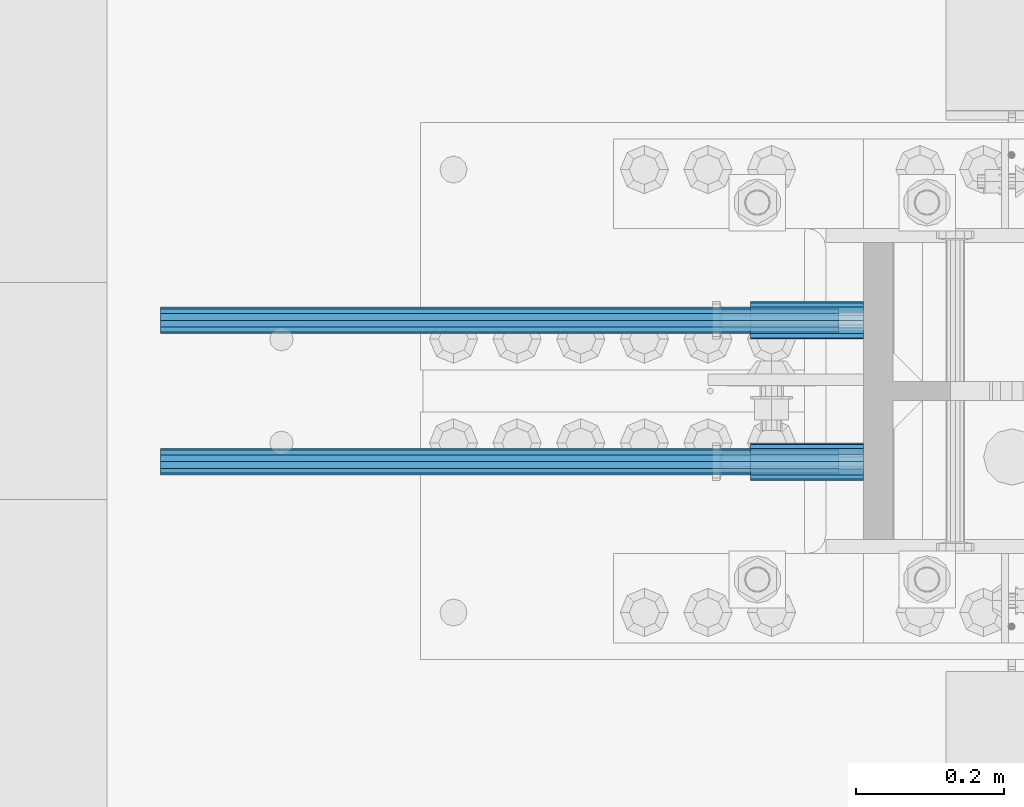
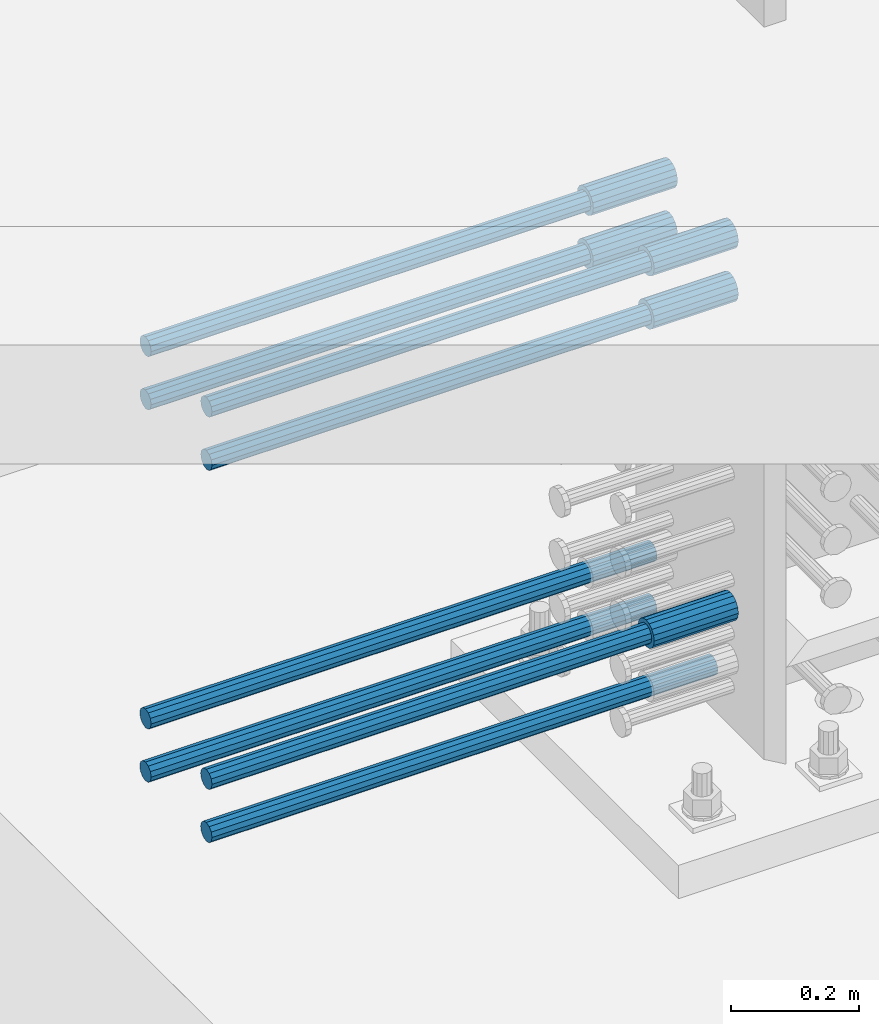
# One storey, part 1236 of 1763: 13 beams, 9 elements without a shape of their own.
"""IFC2X3 building model written with IfcOpenShell, lengths in millimetres."""

from ifc_helpers import new_model, si_unit, frame, origin_with_axes, place, context, subcontext, project, spatial, faceted_brep, material, type_object, element, aggregate, save


model = new_model("IFC2X3")

# Units and contexts
model_context = context("Model", 3, precision=1e-05, world=origin_with_axes())
body_context = subcontext(model_context, "Body", "Model", "MODEL_VIEW")
ifc_project = project(units=[si_unit("LENGTHUNIT", "METRE", prefix="MILLI"), si_unit("AREAUNIT", "SQUARE_METRE"), si_unit("VOLUMEUNIT", "CUBIC_METRE"), si_unit("MASSUNIT", "GRAM", prefix="KILO"), si_unit("TIMEUNIT", "SECOND"), si_unit("PLANEANGLEUNIT", "RADIAN"), si_unit("SOLIDANGLEUNIT", "STERADIAN"), si_unit("THERMODYNAMICTEMPERATUREUNIT", "DEGREE_CELSIUS"), si_unit("LUMINOUSINTENSITYUNIT", "LUMEN")], contexts=[model_context])

# Site, building, storey
site_placement = place(None, origin_with_axes())
site = spatial("IfcSite", under=ifc_project, at=site_placement, CompositionType="ELEMENT")
building_placement = place(site_placement, origin_with_axes())
building = spatial("IfcBuilding", under=site, at=building_placement, Name="Undefined", CompositionType="ELEMENT")
storey_placement = place(building_placement, origin_with_axes())
storey = spatial("IfcBuildingStorey", under=building, at=storey_placement, Name="Undefined", CompositionType="ELEMENT", Elevation=0.0)

# Assembly, beams
assembly_1_placement = place(storey_placement, origin_with_axes())
assembly_1 = element("IfcElementAssembly", 1, at=assembly_1_placement, inside=storey, Name="COLUMN", AssemblyPlace="NOTDEFINED", PredefinedType="RIGID_FRAME")
ifc_material = material(Name="STEEL/A706-GR.80")
beam_type_1 = type_object("IfcBeamType", PredefinedType="NOTDEFINED")
beam_1_placement = place(assembly_1_placement, frame((-35149.8622736972, 361.950000000843, 4165.60000000002), z_axis=(0.0, 0.0, 1.0), x_axis=(-1.0, 0.0, 0.0)))
beam_1 = element("IfcBeam", 2, at=beam_1_placement, type_object=beam_type_1, material=ifc_material, Name="HALF COUPLER F", context=body_context, shape_type="Brep", body=[
    faceted_brep([(32.7659999999996, -8.95349999999962, -15.507916905568), (32.7659999999996, 0.0, -17.9070000000002), (32.7659999999996, 8.95349999999962, -15.507916905568), (32.7659999999996, 15.507916905568, -8.95350000000008), (32.7659999999996, 17.9069999999992, 0.0), (32.7659999999996, 15.507916905568, 8.95350000000008), (32.7659999999996, 8.95349999999962, 15.507916905568), (32.7659999999996, 0.0, 17.9070000000002), (32.7659999999996, -8.95349999999962, 15.507916905568), (32.7659999999996, -15.507916905568, 8.95350000000008), (32.7659999999996, -17.9069999999992, 0.0), (32.7659999999996, -15.507916905568, -8.95350000000008), (152.400103102711, -15.507916905568, 8.95350000000008), (152.400103102711, -8.95349999999962, 15.507916905568), (152.400103102711, -17.9069999999992, 0.0), (152.400103102711, -15.507916905568, -8.95350000000008), (152.400103102711, -8.95349999999962, -15.507916905568), (152.400103102711, 0.0, -17.9070000000002), (152.400103102711, 8.95349999999962, -15.507916905568), (152.400103102711, 15.507916905568, -8.95350000000008), (152.400103102711, 17.9069999999992, 0.0), (152.400103102711, 15.507916905568, 8.95350000000008), (152.400103102711, 8.95349999999962, 15.507916905568), (152.400103102711, 0.0, 17.9070000000002), (0.0, -23.466540125788, 9.72015918207308), (0.0, -17.9605122421381, 17.9605122421385), (0.0, -9.72015918207398, 23.4665401257867), (0.0, 0.0, 25.4000000000001), (0.0, 9.72015918207398, 23.4665401257867), (0.0, 17.9605122421381, 17.9605122421385), (0.0, 23.466540125788, 9.72015918207308), (0.0, 25.4000000000015, 0.0), (0.0, 23.466540125788, -9.72015918207308), (0.0, 17.9605122421381, -17.9605122421385), (0.0, 9.72015918207398, -23.4665401257867), (0.0, 0.0, -25.4000000000001), (0.0, -9.72015918207398, -23.4665401257867), (0.0, -17.9605122421381, -17.9605122421385), (0.0, -23.466540125788, -9.72015918207308), (0.0, -25.4000000000015, 0.0), (152.400103102711, -25.4000000000015, 0.0), (152.400103102711, -23.466540125788, 9.72015918207308), (152.400103102711, -17.9605122421381, 17.9605122421385), (152.400103102711, -9.72015918207398, 23.4665401257867), (152.400103102711, 0.0, 25.4000000000001), (152.400103102711, 9.72015918207398, 23.4665401257867), (152.400103102711, 17.9605122421381, 17.9605122421385), (152.400103102711, 23.466540125788, 9.72015918207308), (152.400103102711, 25.4000000000015, 0.0), (152.400103102711, 23.466540125788, -9.72015918207308), (152.400103102711, 17.9605122421381, -17.9605122421385), (152.400103102711, 9.72015918207398, -23.4665401257867), (152.400103102711, 0.0, -25.4000000000001), (152.400103102711, -9.72015918207398, -23.4665401257867), (152.400103102711, -17.9605122421381, -17.9605122421385), (152.400103102711, -23.466540125788, -9.72015918207308)], [[[0, 1, 2, 3, 4, 5, 6, 7, 8, 9, 10, 11]], [[12, 9, 8, 13]], [[14, 10, 9, 12]], [[15, 11, 10, 14]], [[16, 0, 11, 15]], [[17, 1, 0, 16]], [[18, 2, 1, 17]], [[19, 3, 2, 18]], [[20, 4, 3, 19]], [[21, 5, 4, 20]], [[22, 6, 5, 21]], [[23, 7, 6, 22]], [[13, 8, 7, 23]], [[24, 25, 26, 27, 28, 29, 30, 31, 32, 33, 34, 35, 36, 37, 38, 39]], [[24, 39, 40, 41]], [[25, 24, 41, 42]], [[26, 25, 42, 43]], [[27, 26, 43, 44]], [[28, 27, 44, 45]], [[29, 28, 45, 46]], [[30, 29, 46, 47]], [[31, 30, 47, 48]], [[32, 31, 48, 49]], [[33, 32, 49, 50]], [[34, 33, 50, 51]], [[35, 34, 51, 52]], [[36, 35, 52, 53]], [[37, 36, 53, 54]], [[38, 37, 54, 55]], [[39, 38, 55, 40]], [[54, 53, 52, 51, 50, 49, 48, 47, 46, 45, 44, 43, 42, 41, 40, 55], [21, 20, 19, 18, 17, 16, 15, 14, 12, 13, 23, 22]]]),
])
beam_2_placement = place(assembly_1_placement, frame((-35149.862342359, 552.450000000255, 4775.20000000008), z_axis=(0.0, 0.0, 1.0), x_axis=(-1.0, 0.0, 0.0)))
beam_2 = element("IfcBeam", 3, at=beam_2_placement, type_object=beam_type_1, material=ifc_material, Name="HALF COUPLER", context=body_context, shape_type="Brep", body=[
    faceted_brep([(0.0, -25.4000000000015, 0.0), (0.0, -23.466540125788, -9.72015918207308), (152.400103102711, -23.466540125788, -9.72015918207308), (152.400103102711, -25.4000000000015, 0.0), (0.0, -17.9605122421381, -17.9605122421385), (152.400103102711, -17.9605122421381, -17.9605122421385), (0.0, -9.72015918207398, -23.4665401257867), (152.400103102711, -9.72015918207398, -23.4665401257867), (0.0, 0.0, -25.4000000000001), (152.400103102711, 0.0, -25.4000000000001), (0.0, 9.72015918207398, -23.4665401257867), (152.400103102711, 9.72015918207398, -23.4665401257867), (0.0, 17.9605122421381, -17.9605122421385), (152.400103102711, 17.9605122421381, -17.9605122421385), (0.0, 23.466540125788, -9.72015918207308), (152.400103102711, 23.466540125788, -9.72015918207308), (0.0, 25.4000000000015, 0.0), (152.400103102711, 25.4000000000015, 0.0), (0.0, 23.466540125788, 9.72015918207308), (152.400103102711, 23.466540125788, 9.72015918207308), (0.0, 17.9605122421381, 17.9605122421385), (152.400103102711, 17.9605122421381, 17.9605122421385), (0.0, 9.72015918207398, 23.4665401257867), (152.400103102711, 9.72015918207398, 23.4665401257867), (0.0, 0.0, 25.4000000000001), (152.400103102711, 0.0, 25.4000000000001), (0.0, -9.72015918207398, 23.4665401257867), (152.400103102711, -9.72015918207398, 23.4665401257867), (0.0, -17.9605122421381, 17.9605122421385), (152.400103102711, -17.9605122421381, 17.9605122421385), (0.0, -23.466540125788, 9.72015918207308), (152.400103102711, -23.466540125788, 9.72015918207308)], [[[0, 1, 2, 3]], [[1, 4, 5, 2]], [[4, 6, 7, 5]], [[6, 8, 9, 7]], [[8, 10, 11, 9]], [[10, 12, 13, 11]], [[12, 14, 15, 13]], [[14, 16, 17, 15]], [[16, 18, 19, 17]], [[18, 20, 21, 19]], [[20, 22, 23, 21]], [[22, 24, 25, 23]], [[24, 26, 27, 25]], [[26, 28, 29, 27]], [[28, 30, 31, 29]], [[30, 0, 3, 31]], [[5, 7, 9, 11, 13, 15, 17, 19, 21, 23, 25, 27, 29, 31, 3, 2]], [[30, 28, 26, 24, 22, 20, 18, 16, 14, 12, 10, 8, 6, 4, 1, 0]]]),
])
beam_3_placement = place(assembly_1_placement, frame((-35149.8622736972, 361.950000000843, 4775.20000000008), z_axis=(0.0, 0.0, 1.0), x_axis=(-1.0, 0.0, 0.0)))
beam_3 = element("IfcBeam", 4, at=beam_3_placement, type_object=beam_type_1, material=ifc_material, Name="HALF COUPLER F", context=body_context, shape_type="Brep", body=[
    faceted_brep([(32.7659999999996, -8.95349999999962, -15.507916905568), (32.7659999999996, 0.0, -17.9070000000002), (32.7659999999996, 8.95349999999962, -15.507916905568), (32.7659999999996, 15.507916905568, -8.95350000000008), (32.7659999999996, 17.9069999999992, 0.0), (32.7659999999996, 15.507916905568, 8.95350000000008), (32.7659999999996, 8.95349999999962, 15.507916905568), (32.7659999999996, 0.0, 17.9070000000002), (32.7659999999996, -8.95349999999962, 15.507916905568), (32.7659999999996, -15.507916905568, 8.95350000000008), (32.7659999999996, -17.9069999999992, 0.0), (32.7659999999996, -15.507916905568, -8.95350000000008), (152.400103102711, -15.507916905568, 8.95350000000008), (152.400103102711, -8.95349999999962, 15.507916905568), (152.400103102711, -17.9069999999992, 0.0), (152.400103102711, -15.507916905568, -8.95350000000008), (152.400103102711, -8.95349999999962, -15.507916905568), (152.400103102711, 0.0, -17.9070000000002), (152.400103102711, 8.95349999999962, -15.507916905568), (152.400103102711, 15.507916905568, -8.95350000000008), (152.400103102711, 17.9069999999992, 0.0), (152.400103102711, 15.507916905568, 8.95350000000008), (152.400103102711, 8.95349999999962, 15.507916905568), (152.400103102711, 0.0, 17.9070000000002), (0.0, -23.466540125788, 9.72015918207308), (0.0, -17.9605122421381, 17.9605122421385), (0.0, -9.72015918207398, 23.4665401257867), (0.0, 0.0, 25.4000000000001), (0.0, 9.72015918207398, 23.4665401257867), (0.0, 17.9605122421381, 17.9605122421385), (0.0, 23.466540125788, 9.72015918207308), (0.0, 25.4000000000015, 0.0), (0.0, 23.466540125788, -9.72015918207308), (0.0, 17.9605122421381, -17.9605122421385), (0.0, 9.72015918207398, -23.4665401257867), (0.0, 0.0, -25.4000000000001), (0.0, -9.72015918207398, -23.4665401257867), (0.0, -17.9605122421381, -17.9605122421385), (0.0, -23.466540125788, -9.72015918207308), (0.0, -25.4000000000015, 0.0), (152.400103102711, -25.4000000000015, 0.0), (152.400103102711, -23.466540125788, 9.72015918207308), (152.400103102711, -17.9605122421381, 17.9605122421385), (152.400103102711, -9.72015918207398, 23.4665401257867), (152.400103102711, 0.0, 25.4000000000001), (152.400103102711, 9.72015918207398, 23.4665401257867), (152.400103102711, 17.9605122421381, 17.9605122421385), (152.400103102711, 23.466540125788, 9.72015918207308), (152.400103102711, 25.4000000000015, 0.0), (152.400103102711, 23.466540125788, -9.72015918207308), (152.400103102711, 17.9605122421381, -17.9605122421385), (152.400103102711, 9.72015918207398, -23.4665401257867), (152.400103102711, 0.0, -25.4000000000001), (152.400103102711, -9.72015918207398, -23.4665401257867), (152.400103102711, -17.9605122421381, -17.9605122421385), (152.400103102711, -23.466540125788, -9.72015918207308)], [[[0, 1, 2, 3, 4, 5, 6, 7, 8, 9, 10, 11]], [[12, 9, 8, 13]], [[14, 10, 9, 12]], [[15, 11, 10, 14]], [[16, 0, 11, 15]], [[17, 1, 0, 16]], [[18, 2, 1, 17]], [[19, 3, 2, 18]], [[20, 4, 3, 19]], [[21, 5, 4, 20]], [[22, 6, 5, 21]], [[23, 7, 6, 22]], [[13, 8, 7, 23]], [[24, 25, 26, 27, 28, 29, 30, 31, 32, 33, 34, 35, 36, 37, 38, 39]], [[24, 39, 40, 41]], [[25, 24, 41, 42]], [[26, 25, 42, 43]], [[27, 26, 43, 44]], [[28, 27, 44, 45]], [[29, 28, 45, 46]], [[30, 29, 46, 47]], [[31, 30, 47, 48]], [[32, 31, 48, 49]], [[33, 32, 49, 50]], [[34, 33, 50, 51]], [[35, 34, 51, 52]], [[36, 35, 52, 53]], [[37, 36, 53, 54]], [[38, 37, 54, 55]], [[39, 38, 55, 40]], [[54, 53, 52, 51, 50, 49, 48, 47, 46, 45, 44, 43, 42, 41, 40, 55], [21, 20, 19, 18, 17, 16, 15, 14, 12, 13, 23, 22]]]),
])
beam_4_placement = place(assembly_1_placement, frame((-35149.862342359, 552.450000000255, 4876.80000000008), z_axis=(0.0, 0.0, 1.0), x_axis=(-1.0, 0.0, 0.0)))
beam_4 = element("IfcBeam", 5, at=beam_4_placement, type_object=beam_type_1, material=ifc_material, Name="HALF COUPLER", context=body_context, shape_type="Brep", body=[
    faceted_brep([(0.0, -25.4000000000015, 0.0), (0.0, -23.466540125788, -9.72015918207308), (152.400103102711, -23.466540125788, -9.72015918207308), (152.400103102711, -25.4000000000015, 0.0), (0.0, -17.9605122421381, -17.9605122421385), (152.400103102711, -17.9605122421381, -17.9605122421385), (0.0, -9.72015918207398, -23.4665401257867), (152.400103102711, -9.72015918207398, -23.4665401257867), (0.0, 0.0, -25.4000000000001), (152.400103102711, 0.0, -25.4000000000001), (0.0, 9.72015918207398, -23.4665401257867), (152.400103102711, 9.72015918207398, -23.4665401257867), (0.0, 17.9605122421381, -17.9605122421385), (152.400103102711, 17.9605122421381, -17.9605122421385), (0.0, 23.466540125788, -9.72015918207308), (152.400103102711, 23.466540125788, -9.72015918207308), (0.0, 25.4000000000015, 0.0), (152.400103102711, 25.4000000000015, 0.0), (0.0, 23.466540125788, 9.72015918207308), (152.400103102711, 23.466540125788, 9.72015918207308), (0.0, 17.9605122421381, 17.9605122421385), (152.400103102711, 17.9605122421381, 17.9605122421385), (0.0, 9.72015918207398, 23.4665401257867), (152.400103102711, 9.72015918207398, 23.4665401257867), (0.0, 0.0, 25.4000000000001), (152.400103102711, 0.0, 25.4000000000001), (0.0, -9.72015918207398, 23.4665401257867), (152.400103102711, -9.72015918207398, 23.4665401257867), (0.0, -17.9605122421381, 17.9605122421385), (152.400103102711, -17.9605122421381, 17.9605122421385), (0.0, -23.466540125788, 9.72015918207308), (152.400103102711, -23.466540125788, 9.72015918207308)], [[[0, 1, 2, 3]], [[1, 4, 5, 2]], [[4, 6, 7, 5]], [[6, 8, 9, 7]], [[8, 10, 11, 9]], [[10, 12, 13, 11]], [[12, 14, 15, 13]], [[14, 16, 17, 15]], [[16, 18, 19, 17]], [[18, 20, 21, 19]], [[20, 22, 23, 21]], [[22, 24, 25, 23]], [[24, 26, 27, 25]], [[26, 28, 29, 27]], [[28, 30, 31, 29]], [[30, 0, 3, 31]], [[5, 7, 9, 11, 13, 15, 17, 19, 21, 23, 25, 27, 29, 31, 3, 2]], [[30, 28, 26, 24, 22, 20, 18, 16, 14, 12, 10, 8, 6, 4, 1, 0]]]),
])
beam_5_placement = place(assembly_1_placement, frame((-35149.8622736972, 361.950000000843, 4876.80000000008), z_axis=(0.0, 0.0, 1.0), x_axis=(-1.0, 0.0, 0.0)))
beam_5 = element("IfcBeam", 6, at=beam_5_placement, type_object=beam_type_1, material=ifc_material, Name="HALF COUPLER F", context=body_context, shape_type="Brep", body=[
    faceted_brep([(32.7659999999996, -8.95349999999962, -15.507916905568), (32.7659999999996, 0.0, -17.9070000000002), (32.7659999999996, 8.95349999999962, -15.507916905568), (32.7659999999996, 15.507916905568, -8.95350000000008), (32.7659999999996, 17.9069999999992, 0.0), (32.7659999999996, 15.507916905568, 8.95350000000008), (32.7659999999996, 8.95349999999962, 15.507916905568), (32.7659999999996, 0.0, 17.9070000000002), (32.7659999999996, -8.95349999999962, 15.507916905568), (32.7659999999996, -15.507916905568, 8.95350000000008), (32.7659999999996, -17.9069999999992, 0.0), (32.7659999999996, -15.507916905568, -8.95350000000008), (152.400103102711, -15.507916905568, 8.95350000000008), (152.400103102711, -8.95349999999962, 15.507916905568), (152.400103102711, -17.9069999999992, 0.0), (152.400103102711, -15.507916905568, -8.95350000000008), (152.400103102711, -8.95349999999962, -15.507916905568), (152.400103102711, 0.0, -17.9070000000002), (152.400103102711, 8.95349999999962, -15.507916905568), (152.400103102711, 15.507916905568, -8.95350000000008), (152.400103102711, 17.9069999999992, 0.0), (152.400103102711, 15.507916905568, 8.95350000000008), (152.400103102711, 8.95349999999962, 15.507916905568), (152.400103102711, 0.0, 17.9070000000002), (0.0, -23.466540125788, 9.72015918207308), (0.0, -17.9605122421381, 17.9605122421385), (0.0, -9.72015918207398, 23.4665401257867), (0.0, 0.0, 25.4000000000001), (0.0, 9.72015918207398, 23.4665401257867), (0.0, 17.9605122421381, 17.9605122421385), (0.0, 23.466540125788, 9.72015918207308), (0.0, 25.4000000000015, 0.0), (0.0, 23.466540125788, -9.72015918207308), (0.0, 17.9605122421381, -17.9605122421385), (0.0, 9.72015918207398, -23.4665401257867), (0.0, 0.0, -25.4000000000001), (0.0, -9.72015918207398, -23.4665401257867), (0.0, -17.9605122421381, -17.9605122421385), (0.0, -23.466540125788, -9.72015918207308), (0.0, -25.4000000000015, 0.0), (152.400103102711, -25.4000000000015, 0.0), (152.400103102711, -23.466540125788, 9.72015918207308), (152.400103102711, -17.9605122421381, 17.9605122421385), (152.400103102711, -9.72015918207398, 23.4665401257867), (152.400103102711, 0.0, 25.4000000000001), (152.400103102711, 9.72015918207398, 23.4665401257867), (152.400103102711, 17.9605122421381, 17.9605122421385), (152.400103102711, 23.466540125788, 9.72015918207308), (152.400103102711, 25.4000000000015, 0.0), (152.400103102711, 23.466540125788, -9.72015918207308), (152.400103102711, 17.9605122421381, -17.9605122421385), (152.400103102711, 9.72015918207398, -23.4665401257867), (152.400103102711, 0.0, -25.4000000000001), (152.400103102711, -9.72015918207398, -23.4665401257867), (152.400103102711, -17.9605122421381, -17.9605122421385), (152.400103102711, -23.466540125788, -9.72015918207308)], [[[0, 1, 2, 3, 4, 5, 6, 7, 8, 9, 10, 11]], [[12, 9, 8, 13]], [[14, 10, 9, 12]], [[15, 11, 10, 14]], [[16, 0, 11, 15]], [[17, 1, 0, 16]], [[18, 2, 1, 17]], [[19, 3, 2, 18]], [[20, 4, 3, 19]], [[21, 5, 4, 20]], [[22, 6, 5, 21]], [[23, 7, 6, 22]], [[13, 8, 7, 23]], [[24, 25, 26, 27, 28, 29, 30, 31, 32, 33, 34, 35, 36, 37, 38, 39]], [[24, 39, 40, 41]], [[25, 24, 41, 42]], [[26, 25, 42, 43]], [[27, 26, 43, 44]], [[28, 27, 44, 45]], [[29, 28, 45, 46]], [[30, 29, 46, 47]], [[31, 30, 47, 48]], [[32, 31, 48, 49]], [[33, 32, 49, 50]], [[34, 33, 50, 51]], [[35, 34, 51, 52]], [[36, 35, 52, 53]], [[37, 36, 53, 54]], [[38, 37, 54, 55]], [[39, 38, 55, 40]], [[54, 53, 52, 51, 50, 49, 48, 47, 46, 45, 44, 43, 42, 41, 40, 55], [21, 20, 19, 18, 17, 16, 15, 14, 12, 13, 23, 22]]]),
])
aggregate(assembly_1, [beam_1, beam_2, beam_3, beam_4, beam_5])

# Assembly, beam
assembly_2_placement = place(storey_placement, origin_with_axes())
assembly_2 = element("IfcElementAssembly", 7, at=assembly_2_placement, inside=storey, Name="REBAR", AssemblyPlace="NOTDEFINED", PredefinedType="RIGID_FRAME")
beam_type_2 = type_object("IfcBeamType", Name="#11 REBAR", PredefinedType="NOTDEFINED")
beam_6_placement = place(assembly_2_placement, frame((-35182.6281017452, 361.949999997403, 4063.99999999999), z_axis=(0.0, 0.0, -1.0), x_axis=(-1.0, 0.0, 0.0)))
beam_6 = element("IfcBeam", 8, at=beam_6_placement, type_object=beam_type_2, material=ifc_material, Name="REBAR", ObjectType="#11 REBAR", context=body_context, shape_type="Brep", body=[
    faceted_brep([(0.0, -17.9069999999992, 0.0), (0.0, -15.507916905568, -8.95349999999962), (914.400000001086, -15.507916905568, -8.95349999999962), (914.400000001086, -17.9069999999992, 0.0), (0.0, -8.95349999999962, -15.507916905568), (914.400000001086, -8.95349999999962, -15.507916905568), (0.0, 0.0, -17.9070000000002), (914.400000001086, 0.0, -17.9070000000002), (0.0, 8.95349999999962, -15.507916905568), (914.400000001086, 8.95349999999962, -15.507916905568), (0.0, 15.507916905568, -8.95349999999962), (914.400000001086, 15.507916905568, -8.95349999999962), (0.0, 17.9069999999992, 0.0), (914.400000001086, 17.9069999999992, 0.0), (0.0, 15.507916905568, 8.95349999999962), (914.400000001086, 15.507916905568, 8.95349999999962), (0.0, 8.95349999999962, 15.507916905568), (914.400000001086, 8.95349999999962, 15.507916905568), (0.0, 0.0, 17.9070000000002), (914.400000001086, 0.0, 17.9070000000002), (0.0, -8.95349999999962, 15.507916905568), (914.400000001086, -8.95349999999962, 15.507916905568), (0.0, -15.507916905568, 8.95349999999962), (914.400000001086, -15.507916905568, 8.95349999999962)], [[[0, 1, 2, 3]], [[1, 4, 5, 2]], [[4, 6, 7, 5]], [[6, 8, 9, 7]], [[8, 10, 11, 9]], [[10, 12, 13, 11]], [[12, 14, 15, 13]], [[14, 16, 17, 15]], [[16, 18, 19, 17]], [[18, 20, 21, 19]], [[20, 22, 23, 21]], [[22, 0, 3, 23]], [[5, 7, 9, 11, 13, 15, 17, 19, 21, 23, 3, 2]], [[22, 20, 18, 16, 14, 12, 10, 8, 6, 4, 1, 0]]]),
])
aggregate(assembly_2, [beam_6])

assembly_3_placement = place(storey_placement, origin_with_axes())
assembly_3 = element("IfcElementAssembly", 9, at=assembly_3_placement, inside=storey, Name="REBAR", AssemblyPlace="NOTDEFINED", PredefinedType="RIGID_FRAME")
beam_7_placement = place(assembly_3_placement, frame((-35182.6281705962, 552.449999996816, 4063.99999999999), z_axis=(0.0, 0.0, -1.0), x_axis=(-1.0, 0.0, 0.0)))
beam_7 = element("IfcBeam", 10, at=beam_7_placement, type_object=beam_type_2, material=ifc_material, Name="REBAR", ObjectType="#11 REBAR", context=body_context, shape_type="Brep", body=[
    faceted_brep([(0.0, -17.9069999999992, 0.0), (0.0, -15.507916905568, -8.95349999999962), (914.400000001086, -15.507916905568, -8.95349999999962), (914.400000001086, -17.9069999999992, 0.0), (0.0, -8.95349999999962, -15.507916905568), (914.400000001086, -8.95349999999962, -15.507916905568), (0.0, 0.0, -17.9070000000002), (914.400000001086, 0.0, -17.9070000000002), (0.0, 8.95349999999962, -15.507916905568), (914.400000001086, 8.95349999999962, -15.507916905568), (0.0, 15.507916905568, -8.95349999999962), (914.400000001086, 15.507916905568, -8.95349999999962), (0.0, 17.9069999999992, 0.0), (914.400000001086, 17.9069999999992, 0.0), (0.0, 15.507916905568, 8.95349999999962), (914.400000001086, 15.507916905568, 8.95349999999962), (0.0, 8.95349999999962, 15.507916905568), (914.400000001086, 8.95349999999962, 15.507916905568), (0.0, 0.0, 17.9070000000002), (914.400000001086, 0.0, 17.9070000000002), (0.0, -8.95349999999962, 15.507916905568), (914.400000001086, -8.95349999999962, 15.507916905568), (0.0, -15.507916905568, 8.95349999999962), (914.400000001086, -15.507916905568, 8.95349999999962)], [[[0, 1, 2, 3]], [[1, 4, 5, 2]], [[4, 6, 7, 5]], [[6, 8, 9, 7]], [[8, 10, 11, 9]], [[10, 12, 13, 11]], [[12, 14, 15, 13]], [[14, 16, 17, 15]], [[16, 18, 19, 17]], [[18, 20, 21, 19]], [[20, 22, 23, 21]], [[22, 0, 3, 23]], [[5, 7, 9, 11, 13, 15, 17, 19, 21, 23, 3, 2]], [[22, 20, 18, 16, 14, 12, 10, 8, 6, 4, 1, 0]]]),
])
aggregate(assembly_3, [beam_7])

assembly_4_placement = place(storey_placement, origin_with_axes())
assembly_4 = element("IfcElementAssembly", 11, at=assembly_4_placement, inside=storey, Name="REBAR", AssemblyPlace="NOTDEFINED", PredefinedType="RIGID_FRAME")
beam_8_placement = place(assembly_4_placement, frame((-35182.6281017452, 361.949999997407, 4165.59999999999), z_axis=(0.0, 0.0, -1.0), x_axis=(-1.0, 0.0, 0.0)))
beam_8 = element("IfcBeam", 12, at=beam_8_placement, type_object=beam_type_2, material=ifc_material, Name="REBAR", ObjectType="#11 REBAR", context=body_context, shape_type="Brep", body=[
    faceted_brep([(0.0, -17.9069999999992, 0.0), (0.0, -15.507916905568, -8.95349999999962), (914.400000001086, -15.507916905568, -8.95349999999962), (914.400000001086, -17.9069999999992, 0.0), (0.0, -8.95349999999962, -15.507916905568), (914.400000001086, -8.95349999999962, -15.507916905568), (0.0, 0.0, -17.9070000000002), (914.400000001086, 0.0, -17.9070000000002), (0.0, 8.95349999999962, -15.507916905568), (914.400000001086, 8.95349999999962, -15.507916905568), (0.0, 15.507916905568, -8.95349999999962), (914.400000001086, 15.507916905568, -8.95349999999962), (0.0, 17.9069999999992, 0.0), (914.400000001086, 17.9069999999992, 0.0), (0.0, 15.507916905568, 8.95349999999962), (914.400000001086, 15.507916905568, 8.95349999999962), (0.0, 8.95349999999962, 15.507916905568), (914.400000001086, 8.95349999999962, 15.507916905568), (0.0, 0.0, 17.9070000000002), (914.400000001086, 0.0, 17.9070000000002), (0.0, -8.95349999999962, 15.507916905568), (914.400000001086, -8.95349999999962, 15.507916905568), (0.0, -15.507916905568, 8.95349999999962), (914.400000001086, -15.507916905568, 8.95349999999962)], [[[0, 1, 2, 3]], [[1, 4, 5, 2]], [[4, 6, 7, 5]], [[6, 8, 9, 7]], [[8, 10, 11, 9]], [[10, 12, 13, 11]], [[12, 14, 15, 13]], [[14, 16, 17, 15]], [[16, 18, 19, 17]], [[18, 20, 21, 19]], [[20, 22, 23, 21]], [[22, 0, 3, 23]], [[5, 7, 9, 11, 13, 15, 17, 19, 21, 23, 3, 2]], [[22, 20, 18, 16, 14, 12, 10, 8, 6, 4, 1, 0]]]),
])
aggregate(assembly_4, [beam_8])

assembly_5_placement = place(storey_placement, origin_with_axes())
assembly_5 = element("IfcElementAssembly", 13, at=assembly_5_placement, inside=storey, Name="REBAR", AssemblyPlace="NOTDEFINED", PredefinedType="RIGID_FRAME")
beam_9_placement = place(assembly_5_placement, frame((-35182.6281705962, 552.449999996819, 4165.59999999999), z_axis=(0.0, 0.0, -1.0), x_axis=(-1.0, 0.0, 0.0)))
beam_9 = element("IfcBeam", 14, at=beam_9_placement, type_object=beam_type_2, material=ifc_material, Name="REBAR", ObjectType="#11 REBAR", context=body_context, shape_type="Brep", body=[
    faceted_brep([(0.0, -17.9069999999992, 0.0), (0.0, -15.507916905568, -8.95349999999962), (914.400000001086, -15.507916905568, -8.95349999999962), (914.400000001086, -17.9069999999992, 0.0), (0.0, -8.95349999999962, -15.507916905568), (914.400000001086, -8.95349999999962, -15.507916905568), (0.0, 0.0, -17.9070000000002), (914.400000001086, 0.0, -17.9070000000002), (0.0, 8.95349999999962, -15.507916905568), (914.400000001086, 8.95349999999962, -15.507916905568), (0.0, 15.507916905568, -8.95349999999962), (914.400000001086, 15.507916905568, -8.95349999999962), (0.0, 17.9069999999992, 0.0), (914.400000001086, 17.9069999999992, 0.0), (0.0, 15.507916905568, 8.95349999999962), (914.400000001086, 15.507916905568, 8.95349999999962), (0.0, 8.95349999999962, 15.507916905568), (914.400000001086, 8.95349999999962, 15.507916905568), (0.0, 0.0, 17.9070000000002), (914.400000001086, 0.0, 17.9070000000002), (0.0, -8.95349999999962, 15.507916905568), (914.400000001086, -8.95349999999962, 15.507916905568), (0.0, -15.507916905568, 8.95349999999962), (914.400000001086, -15.507916905568, 8.95349999999962)], [[[0, 1, 2, 3]], [[1, 4, 5, 2]], [[4, 6, 7, 5]], [[6, 8, 9, 7]], [[8, 10, 11, 9]], [[10, 12, 13, 11]], [[12, 14, 15, 13]], [[14, 16, 17, 15]], [[16, 18, 19, 17]], [[18, 20, 21, 19]], [[20, 22, 23, 21]], [[22, 0, 3, 23]], [[5, 7, 9, 11, 13, 15, 17, 19, 21, 23, 3, 2]], [[22, 20, 18, 16, 14, 12, 10, 8, 6, 4, 1, 0]]]),
])
aggregate(assembly_5, [beam_9])

assembly_6_placement = place(storey_placement, origin_with_axes())
assembly_6 = element("IfcElementAssembly", 15, at=assembly_6_placement, inside=storey, Name="REBAR", AssemblyPlace="NOTDEFINED", PredefinedType="RIGID_FRAME")
beam_10_placement = place(assembly_6_placement, frame((-35182.6281704807, 361.949999998675, 4775.20000000006), z_axis=(0.0, 0.0, -1.0), x_axis=(-1.0, 0.0, 0.0)))
beam_10 = element("IfcBeam", 16, at=beam_10_placement, type_object=beam_type_2, material=ifc_material, Name="REBAR", ObjectType="#11 REBAR", context=body_context, shape_type="Brep", body=[
    faceted_brep([(0.0, -17.9069999999992, 0.0), (0.0, -15.507916905568, -8.95349999999962), (914.400000001086, -15.507916905568, -8.95349999999962), (914.400000001086, -17.9069999999992, 0.0), (0.0, -8.95349999999962, -15.507916905568), (914.400000001086, -8.95349999999962, -15.507916905568), (0.0, 0.0, -17.9070000000002), (914.400000001086, 0.0, -17.9070000000002), (0.0, 8.95349999999962, -15.507916905568), (914.400000001086, 8.95349999999962, -15.507916905568), (0.0, 15.507916905568, -8.95349999999962), (914.400000001086, 15.507916905568, -8.95349999999962), (0.0, 17.9069999999992, 0.0), (914.400000001086, 17.9069999999992, 0.0), (0.0, 15.507916905568, 8.95349999999962), (914.400000001086, 15.507916905568, 8.95349999999962), (0.0, 8.95349999999962, 15.507916905568), (914.400000001086, 8.95349999999962, 15.507916905568), (0.0, 0.0, 17.9070000000002), (914.400000001086, 0.0, 17.9070000000002), (0.0, -8.95349999999962, 15.507916905568), (914.400000001086, -8.95349999999962, 15.507916905568), (0.0, -15.507916905568, 8.95349999999962), (914.400000001086, -15.507916905568, 8.95349999999962)], [[[0, 1, 2, 3]], [[1, 4, 5, 2]], [[4, 6, 7, 5]], [[6, 8, 9, 7]], [[8, 10, 11, 9]], [[10, 12, 13, 11]], [[12, 14, 15, 13]], [[14, 16, 17, 15]], [[16, 18, 19, 17]], [[18, 20, 21, 19]], [[20, 22, 23, 21]], [[22, 0, 3, 23]], [[5, 7, 9, 11, 13, 15, 17, 19, 21, 23, 3, 2]], [[22, 20, 18, 16, 14, 12, 10, 8, 6, 4, 1, 0]]]),
])
aggregate(assembly_6, [beam_10])

assembly_7_placement = place(storey_placement, origin_with_axes())
assembly_7 = element("IfcElementAssembly", 17, at=assembly_7_placement, inside=storey, Name="REBAR", AssemblyPlace="NOTDEFINED", PredefinedType="RIGID_FRAME")
beam_11_placement = place(assembly_7_placement, frame((-35182.6282393324, 552.449999998087, 4775.20000000006), z_axis=(0.0, 0.0, -1.0), x_axis=(-1.0, 0.0, 0.0)))
beam_11 = element("IfcBeam", 18, at=beam_11_placement, type_object=beam_type_2, material=ifc_material, Name="REBAR", ObjectType="#11 REBAR", context=body_context, shape_type="Brep", body=[
    faceted_brep([(0.0, -17.9069999999992, 0.0), (0.0, -15.507916905568, -8.95349999999962), (914.400000001086, -15.507916905568, -8.95349999999962), (914.400000001086, -17.9069999999992, 0.0), (0.0, -8.95349999999962, -15.507916905568), (914.400000001086, -8.95349999999962, -15.507916905568), (0.0, 0.0, -17.9070000000002), (914.400000001086, 0.0, -17.9070000000002), (0.0, 8.95349999999962, -15.507916905568), (914.400000001086, 8.95349999999962, -15.507916905568), (0.0, 15.507916905568, -8.95349999999962), (914.400000001086, 15.507916905568, -8.95349999999962), (0.0, 17.9069999999992, 0.0), (914.400000001086, 17.9069999999992, 0.0), (0.0, 15.507916905568, 8.95349999999962), (914.400000001086, 15.507916905568, 8.95349999999962), (0.0, 8.95349999999962, 15.507916905568), (914.400000001086, 8.95349999999962, 15.507916905568), (0.0, 0.0, 17.9070000000002), (914.400000001086, 0.0, 17.9070000000002), (0.0, -8.95349999999962, 15.507916905568), (914.400000001086, -8.95349999999962, 15.507916905568), (0.0, -15.507916905568, 8.95349999999962), (914.400000001086, -15.507916905568, 8.95349999999962)], [[[0, 1, 2, 3]], [[1, 4, 5, 2]], [[4, 6, 7, 5]], [[6, 8, 9, 7]], [[8, 10, 11, 9]], [[10, 12, 13, 11]], [[12, 14, 15, 13]], [[14, 16, 17, 15]], [[16, 18, 19, 17]], [[18, 20, 21, 19]], [[20, 22, 23, 21]], [[22, 0, 3, 23]], [[5, 7, 9, 11, 13, 15, 17, 19, 21, 23, 3, 2]], [[22, 20, 18, 16, 14, 12, 10, 8, 6, 4, 1, 0]]]),
])
aggregate(assembly_7, [beam_11])

assembly_8_placement = place(storey_placement, origin_with_axes())
assembly_8 = element("IfcElementAssembly", 19, at=assembly_8_placement, inside=storey, Name="REBAR", AssemblyPlace="NOTDEFINED", PredefinedType="RIGID_FRAME")
beam_12_placement = place(assembly_8_placement, frame((-35182.6281704807, 361.949999998678, 4876.80000000006), z_axis=(0.0, 0.0, -1.0), x_axis=(-1.0, 0.0, 0.0)))
beam_12 = element("IfcBeam", 20, at=beam_12_placement, type_object=beam_type_2, material=ifc_material, Name="REBAR", ObjectType="#11 REBAR", context=body_context, shape_type="Brep", body=[
    faceted_brep([(0.0, -17.9069999999992, 0.0), (0.0, -15.507916905568, -8.95349999999962), (914.400000001086, -15.507916905568, -8.95349999999962), (914.400000001086, -17.9069999999992, 0.0), (0.0, -8.95349999999962, -15.507916905568), (914.400000001086, -8.95349999999962, -15.507916905568), (0.0, 0.0, -17.9070000000002), (914.400000001086, 0.0, -17.9070000000002), (0.0, 8.95349999999962, -15.507916905568), (914.400000001086, 8.95349999999962, -15.507916905568), (0.0, 15.507916905568, -8.95349999999962), (914.400000001086, 15.507916905568, -8.95349999999962), (0.0, 17.9069999999992, 0.0), (914.400000001086, 17.9069999999992, 0.0), (0.0, 15.507916905568, 8.95349999999962), (914.400000001086, 15.507916905568, 8.95349999999962), (0.0, 8.95349999999962, 15.507916905568), (914.400000001086, 8.95349999999962, 15.507916905568), (0.0, 0.0, 17.9070000000002), (914.400000001086, 0.0, 17.9070000000002), (0.0, -8.95349999999962, 15.507916905568), (914.400000001086, -8.95349999999962, 15.507916905568), (0.0, -15.507916905568, 8.95349999999962), (914.400000001086, -15.507916905568, 8.95349999999962)], [[[0, 1, 2, 3]], [[1, 4, 5, 2]], [[4, 6, 7, 5]], [[6, 8, 9, 7]], [[8, 10, 11, 9]], [[10, 12, 13, 11]], [[12, 14, 15, 13]], [[14, 16, 17, 15]], [[16, 18, 19, 17]], [[18, 20, 21, 19]], [[20, 22, 23, 21]], [[22, 0, 3, 23]], [[5, 7, 9, 11, 13, 15, 17, 19, 21, 23, 3, 2]], [[22, 20, 18, 16, 14, 12, 10, 8, 6, 4, 1, 0]]]),
])
aggregate(assembly_8, [beam_12])

assembly_9_placement = place(storey_placement, origin_with_axes())
assembly_9 = element("IfcElementAssembly", 21, at=assembly_9_placement, inside=storey, Name="REBAR", AssemblyPlace="NOTDEFINED", PredefinedType="RIGID_FRAME")
beam_13_placement = place(assembly_9_placement, frame((-35182.6282393324, 552.449999998091, 4876.80000000006), z_axis=(0.0, 0.0, -1.0), x_axis=(-1.0, 0.0, 0.0)))
beam_13 = element("IfcBeam", 22, at=beam_13_placement, type_object=beam_type_2, material=ifc_material, Name="REBAR", ObjectType="#11 REBAR", context=body_context, shape_type="Brep", body=[
    faceted_brep([(0.0, -17.9069999999992, 0.0), (0.0, -15.507916905568, -8.95349999999962), (914.400000001086, -15.507916905568, -8.95349999999962), (914.400000001086, -17.9069999999992, 0.0), (0.0, -8.95349999999962, -15.507916905568), (914.400000001086, -8.95349999999962, -15.507916905568), (0.0, 0.0, -17.9070000000002), (914.400000001086, 0.0, -17.9070000000002), (0.0, 8.95349999999962, -15.507916905568), (914.400000001086, 8.95349999999962, -15.507916905568), (0.0, 15.507916905568, -8.95349999999962), (914.400000001086, 15.507916905568, -8.95349999999962), (0.0, 17.9069999999992, 0.0), (914.400000001086, 17.9069999999992, 0.0), (0.0, 15.507916905568, 8.95349999999962), (914.400000001086, 15.507916905568, 8.95349999999962), (0.0, 8.95349999999962, 15.507916905568), (914.400000001086, 8.95349999999962, 15.507916905568), (0.0, 0.0, 17.9070000000002), (914.400000001086, 0.0, 17.9070000000002), (0.0, -8.95349999999962, 15.507916905568), (914.400000001086, -8.95349999999962, 15.507916905568), (0.0, -15.507916905568, 8.95349999999962), (914.400000001086, -15.507916905568, 8.95349999999962)], [[[0, 1, 2, 3]], [[1, 4, 5, 2]], [[4, 6, 7, 5]], [[6, 8, 9, 7]], [[8, 10, 11, 9]], [[10, 12, 13, 11]], [[12, 14, 15, 13]], [[14, 16, 17, 15]], [[16, 18, 19, 17]], [[18, 20, 21, 19]], [[20, 22, 23, 21]], [[22, 0, 3, 23]], [[5, 7, 9, 11, 13, 15, 17, 19, 21, 23, 3, 2]], [[22, 20, 18, 16, 14, 12, 10, 8, 6, 4, 1, 0]]]),
])
aggregate(assembly_9, [beam_13])

save(model, "model.ifc")
